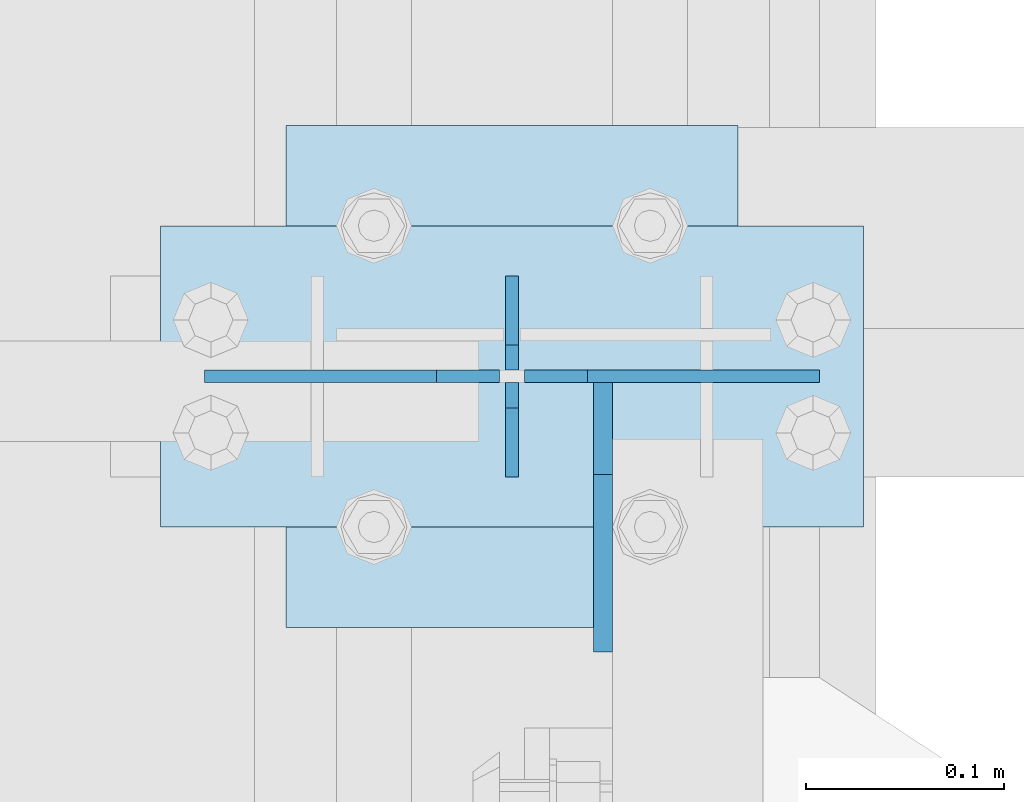
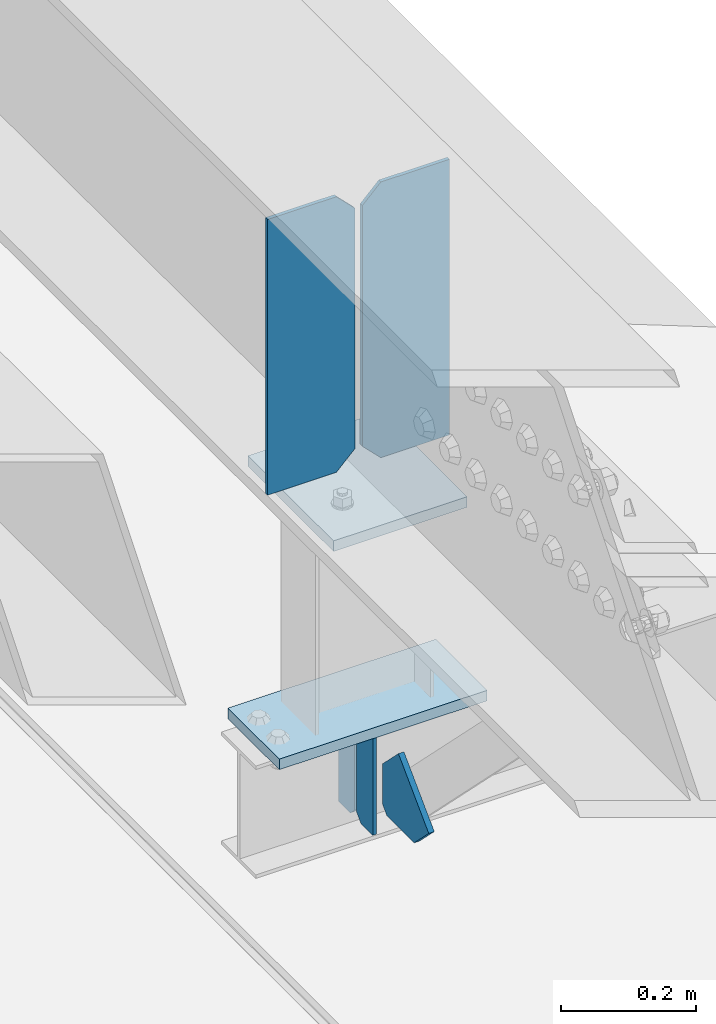
# One storey, part 3276 of 3843: 7 plates, 3 elements without a shape of their own.
"""IFC2X3 building model written with IfcOpenShell, lengths in millimetres."""

from ifc_helpers import new_model, si_unit, frame, origin_with_axes, place, context, subcontext, project, spatial, faceted_brep, material, type_object, element, aggregate, save


model = new_model("IFC2X3")

# Units and contexts
model_context = context("Model", 3, precision=1e-05, world=origin_with_axes())
body_context = subcontext(model_context, "Body", "Model", "MODEL_VIEW")
ifc_project = project(units=[si_unit("LENGTHUNIT", "METRE", prefix="MILLI"), si_unit("AREAUNIT", "SQUARE_METRE"), si_unit("VOLUMEUNIT", "CUBIC_METRE"), si_unit("MASSUNIT", "GRAM", prefix="KILO"), si_unit("TIMEUNIT", "SECOND"), si_unit("PLANEANGLEUNIT", "RADIAN"), si_unit("SOLIDANGLEUNIT", "STERADIAN"), si_unit("THERMODYNAMICTEMPERATUREUNIT", "DEGREE_CELSIUS"), si_unit("LUMINOUSINTENSITYUNIT", "LUMEN")], contexts=[model_context])

# Site, building, storey
site_placement = place(None, origin_with_axes())
site = spatial("IfcSite", under=ifc_project, at=site_placement, CompositionType="ELEMENT")
building_placement = place(site_placement, origin_with_axes())
building = spatial("IfcBuilding", under=site, at=building_placement, Name="Undefined", CompositionType="ELEMENT")
storey_placement = place(building_placement, origin_with_axes())
storey = spatial("IfcBuildingStorey", under=building, at=storey_placement, Name="Undefined", CompositionType="ELEMENT", Elevation=0.0)

# Assembly, plates
assembly_1_placement = place(storey_placement, origin_with_axes())
assembly_1 = element("IfcElementAssembly", 1, at=assembly_1_placement, inside=storey, Name="BEAM", AssemblyPlace="NOTDEFINED", PredefinedType="RIGID_FRAME")
ifc_material = material(Name="STEEL/A572-50")
plate_type_1 = type_object("IfcPlateType", PredefinedType="NOTDEFINED")
plate_1_placement = place(assembly_1_placement, frame((36576.0000030517, 60337.7, 41495.6625), z_axis=(0.0, 0.0, -1.0), x_axis=(0.0, -1.0, 0.0)))
plate_1 = element("IfcPlate", 2, at=plate_1_placement, type_object=plate_type_1, material=ifc_material, Name="PLATE", context=body_context, shape_type="Brep", body=[
    faceted_brep([(0.0, -3.17499999999927, 0.0), (0.0, -3.17500000000291, 187.324999999997), (0.0, 3.17500000000291, 187.324999999997), (0.0, 3.17499999999927, 0.0), (34.9250001907349, -3.17500000000291, 187.324999999997), (34.9250001907349, 3.17500000000291, 187.324999999997), (47.625, -3.17500000000291, 174.625000190732), (47.625, 3.17500000000291, 174.625000190732), (47.625, -3.17499999999927, 12.6999998092651), (47.625, 3.17499999999927, 12.6999998092651), (34.9250001907349, -3.17499999999927, 0.0), (34.9250001907349, 3.17499999999927, 0.0)], [[[0, 1, 2, 3]], [[1, 4, 5, 2]], [[4, 6, 7, 5]], [[6, 8, 9, 7]], [[8, 10, 11, 9]], [[10, 0, 3, 11]], [[5, 7, 9, 11, 3, 2]], [[10, 8, 6, 4, 1, 0]]]),
])
plate_2_placement = place(assembly_1_placement, frame((36576.0000030517, 60236.1, 41495.6625), z_axis=(0.0, 0.0, -1.0), x_axis=(0.0, 1.0, 0.0)))
plate_2 = element("IfcPlate", 3, at=plate_2_placement, type_object=plate_type_1, material=ifc_material, Name="PLATE", context=body_context, shape_type="Brep", body=[
    faceted_brep([(0.0, -3.17499999999927, 0.0), (0.0, -3.17500000000291, 187.324999999997), (0.0, 3.17500000000291, 187.324999999997), (0.0, 3.17499999999927, 0.0), (34.9250001907349, -3.17500000000291, 187.324999999997), (34.9250001907349, 3.17500000000291, 187.324999999997), (47.625, -3.17500000000291, 174.625000190732), (47.625, 3.17500000000291, 174.625000190732), (47.625, -3.17499999999927, 12.6999998092651), (47.625, 3.17499999999927, 12.6999998092651), (34.9250001907349, -3.17499999999927, 0.0), (34.9250001907349, 3.17499999999927, 0.0)], [[[0, 1, 2, 3]], [[1, 4, 5, 2]], [[4, 6, 7, 5]], [[6, 8, 9, 7]], [[8, 10, 11, 9]], [[10, 0, 3, 11]], [[5, 7, 9, 11, 3, 2]], [[10, 8, 6, 4, 1, 0]]]),
])

# Assembly, plate
assembly_2_placement = place(storey_placement, origin_with_axes())
assembly_2 = element("IfcElementAssembly", 4, at=assembly_2_placement, inside=storey, Name="POST", AssemblyPlace="NOTDEFINED", PredefinedType="RIGID_FRAME")
plate_type_2 = type_object("IfcPlateType", PredefinedType="NOTDEFINED")
plate_3_placement = place(assembly_2_placement, frame((36753.8000030518, 60210.7, 41513.125), z_axis=(-1.0, 0.0, 0.0), x_axis=(0.0, 1.0, 0.0)))
plate_3 = element("IfcPlate", 5, at=plate_3_placement, type_object=plate_type_2, material=ifc_material, Name="PLATE", context=body_context, shape_type="Brep", body=[
    faceted_brep([(0.0, -9.52500000000146, 0.0), (0.0, -9.52500000000146, 355.599999999999), (0.0, 9.52500000000146, 355.599999999999), (0.0, 9.52500000000146, 0.0), (152.399999999994, -9.52500000000146, 355.599999999999), (152.399999999994, 9.52500000000146, 355.599999999999), (152.400000000001, -9.52500000000146, 0.0), (152.400000000001, 9.52500000000146, 0.0)], [[[0, 1, 2, 3]], [[1, 4, 5, 2]], [[4, 6, 7, 5]], [[6, 0, 3, 7]], [[5, 7, 3, 2]], [[6, 4, 1, 0]]]),
])

# Assembly, plates
assembly_3_placement = place(storey_placement, origin_with_axes())
assembly_3 = element("IfcElementAssembly", 6, at=assembly_3_placement, inside=storey, Name="BEAM", AssemblyPlace="NOTDEFINED", PredefinedType="RIGID_FRAME")
plate_type_3 = type_object("IfcPlateType", PredefinedType="NOTDEFINED")
plate_4_placement = place(assembly_3_placement, frame((36731.575, 60286.9, 42446.575), z_axis=(0.0, 0.0, -1.0), x_axis=(-1.0, 0.0, 0.0)))
plate_4 = element("IfcPlate", 7, at=plate_4_placement, type_object=plate_type_3, material=ifc_material, Name="PLATE", context=body_context, shape_type="Brep", body=[
    faceted_brep([(0.0, -3.17499999999927, 0.0), (0.0, -3.17500000000291, 498.475000000006), (0.0, 3.17500000000291, 498.475000000006), (0.0, 3.17499999999927, 0.0), (117.475000000006, -3.17500000000291, 498.475000000006), (117.475000000006, 3.17500000000291, 498.475000000006), (149.225000000006, -3.17500000000291, 466.725000000006), (149.225000000006, 3.17500000000291, 466.725000000006), (149.225000000006, -3.17500000000291, 31.75), (149.225000000006, 3.17500000000291, 31.75), (117.475000000006, -3.17500000000291, 0.0), (117.475000000006, 3.17500000000291, 0.0)], [[[0, 1, 2, 3]], [[1, 4, 5, 2]], [[4, 6, 7, 5]], [[6, 8, 9, 7]], [[8, 10, 11, 9]], [[10, 0, 3, 11]], [[5, 7, 9, 11, 3, 2]], [[10, 8, 6, 4, 1, 0]]]),
])
plate_5_placement = place(assembly_3_placement, frame((36420.425, 60286.9, 42446.575), z_axis=(0.0, 0.0, -1.0), x_axis=(1.0, 0.0, 0.0)))
plate_5 = element("IfcPlate", 8, at=plate_5_placement, type_object=plate_type_3, material=ifc_material, Name="PLATE", context=body_context, shape_type="Brep", body=[
    faceted_brep([(0.0, -3.17499999999927, 0.0), (0.0, -3.17500000000291, 498.475000000006), (0.0, 3.17500000000291, 498.475000000006), (0.0, 3.17499999999927, 0.0), (117.475000000006, -3.17500000000291, 498.475000000006), (117.475000000006, 3.17500000000291, 498.475000000006), (149.225000000006, -3.17500000000291, 466.725000000006), (149.225000000006, 3.17500000000291, 466.725000000006), (149.225000000006, -3.17500000000291, 31.75), (149.225000000006, 3.17500000000291, 31.75), (117.475000000006, -3.17500000000291, 0.0), (117.475000000006, 3.17500000000291, 0.0)], [[[0, 1, 2, 3]], [[1, 4, 5, 2]], [[4, 6, 7, 5]], [[6, 8, 9, 7]], [[8, 10, 11, 9]], [[10, 0, 3, 11]], [[5, 7, 9, 11, 3, 2]], [[10, 8, 6, 4, 1, 0]]]),
])
aggregate(assembly_3, [plate_4, plate_5])

# Plate
plate_type_4 = type_object("IfcPlateType", PredefinedType="NOTDEFINED")
plate_6_placement = place(assembly_2_placement, frame((36461.7000005181, 60413.9, 41916.35), z_axis=(0.0, -1.0, 0.0), x_axis=(1.0, 0.0, 0.0)))
plate_6 = element("IfcPlate", 9, at=plate_6_placement, type_object=plate_type_4, material=ifc_material, Name="PLATE", context=body_context, shape_type="Brep", body=[
    faceted_brep([(0.0, -9.52500000000146, 0.0), (0.0, -9.52500000000146, 254.0), (0.0, 9.52500000000146, 254.0), (0.0, 9.52500000000146, 0.0), (228.599999999999, -9.52500000000146, 254.0), (228.599999999999, 9.52500000000146, 254.0), (228.599999999999, -9.52500000000146, 0.0), (228.599999999999, 9.52500000000146, 0.0)], [[[0, 1, 2, 3]], [[1, 4, 5, 2]], [[4, 6, 7, 5]], [[6, 0, 3, 7]], [[5, 7, 3, 2]], [[6, 4, 1, 0]]]),
])

aggregate(assembly_2, [plate_6, plate_3])

plate_type_5 = type_object("IfcPlateType", PredefinedType="NOTDEFINED")
plate_7_placement = place(assembly_1_placement, frame((36622.0375, 60283.725, 41306.75), z_axis=(0.0, -1.0, 0.0), x_axis=(0.0, 0.0, 1.0)))
plate_7 = element("IfcPlate", 10, at=plate_7_placement, type_object=plate_type_5, material=ifc_material, Name="PLATE", context=body_context, shape_type="Brep", body=[
    faceted_brep([(0.0, -4.76250000000073, 12.6999998092651), (4.450703272596e-08, -4.76249999999709, 93.0710244828806), (4.450703272596e-08, 4.76249999999709, 93.0710244828806), (0.0, 4.76250000000073, 12.6999998092651), (43.3137807601452, -4.76249999999709, 136.384805065652), (43.3137807601452, 4.76249999999709, 136.384805065652), (133.209805202001, -4.76249999999709, 46.4887805392646), (133.209805202001, 4.76249999999709, 46.4887805392646), (86.7210245267561, -4.76249999999709, 0.0), (86.7210245267561, 4.76249999999709, 0.0), (12.6999998092651, -4.76250000000073, 0.0), (12.6999998092651, 4.76250000000073, 0.0)], [[[0, 1, 2, 3]], [[1, 4, 5, 2]], [[4, 6, 7, 5]], [[6, 8, 9, 7]], [[8, 10, 11, 9]], [[10, 0, 3, 11]], [[5, 7, 9, 11, 3, 2]], [[10, 8, 6, 4, 1, 0]]]),
])

aggregate(assembly_1, [plate_1, plate_2, plate_7])

save(model, "model.ifc")
